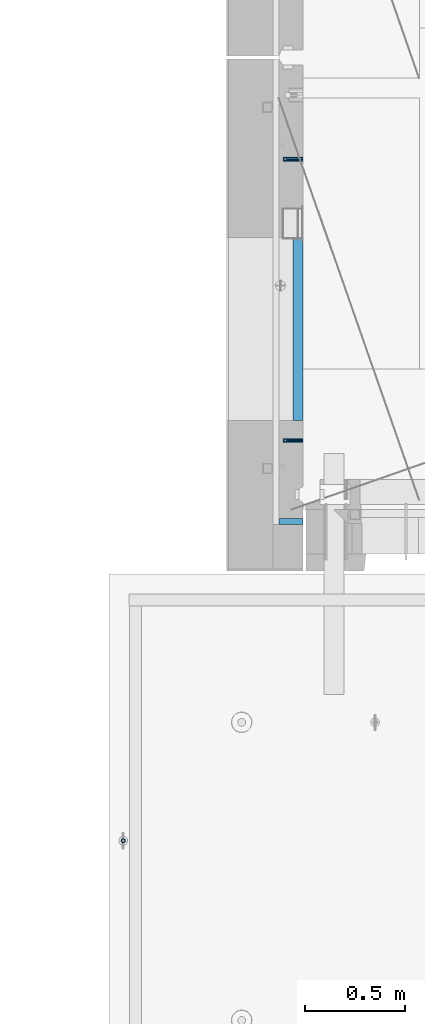
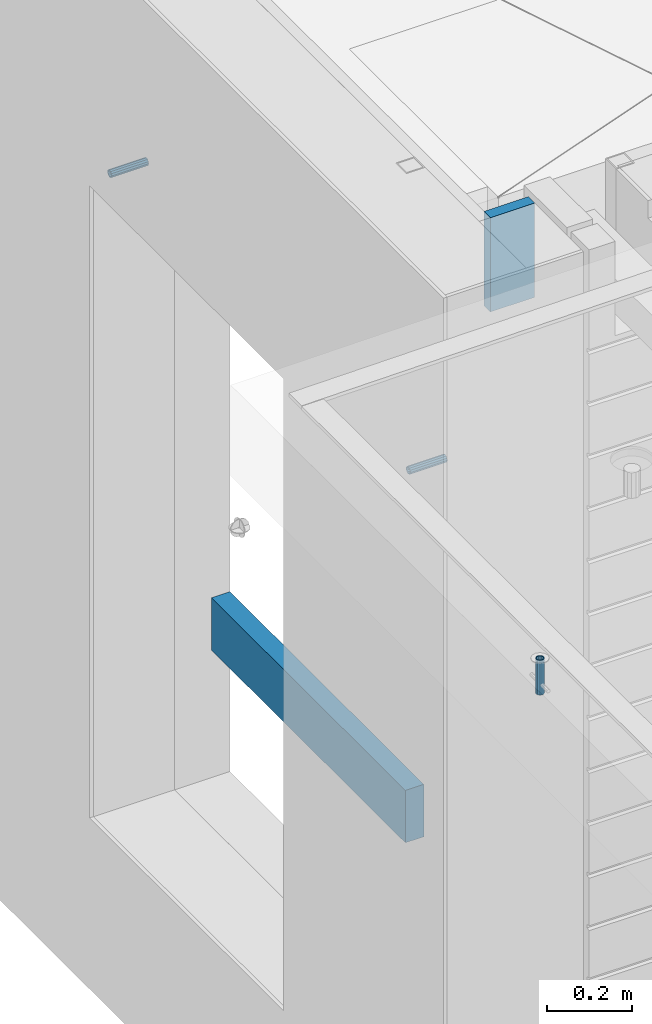
# One storey, part 138 of 350: 5 beams, 5 elements without a shape of their own.
"""IFC2X3 building model written with IfcOpenShell, lengths in millimetres."""

from ifc_helpers import new_model, si_unit, frame, origin_with_axes, place, context, subcontext, project, spatial, faceted_brep, material, type_object, element, aggregate, save


model = new_model("IFC2X3")

# Units and contexts
model_context = context("Model", 3, precision=1e-05, world=origin_with_axes())
body_context = subcontext(model_context, "Body", "Model", "MODEL_VIEW")
ifc_project = project(units=[si_unit("LENGTHUNIT", "METRE", prefix="MILLI"), si_unit("AREAUNIT", "SQUARE_METRE"), si_unit("VOLUMEUNIT", "CUBIC_METRE"), si_unit("MASSUNIT", "GRAM", prefix="KILO"), si_unit("TIMEUNIT", "SECOND"), si_unit("PLANEANGLEUNIT", "RADIAN"), si_unit("SOLIDANGLEUNIT", "STERADIAN"), si_unit("THERMODYNAMICTEMPERATUREUNIT", "DEGREE_CELSIUS"), si_unit("LUMINOUSINTENSITYUNIT", "LUMEN")], contexts=[model_context])

# Site, building, storey
site_placement = place(None, origin_with_axes())
site = spatial("IfcSite", under=ifc_project, at=site_placement, CompositionType="ELEMENT")
building_placement = place(site_placement, origin_with_axes())
building = spatial("IfcBuilding", under=site, at=building_placement, CompositionType="ELEMENT")
storey_placement = place(building_placement, origin_with_axes())
storey = spatial("IfcBuildingStorey", under=building, at=storey_placement, Name="2", CompositionType="ELEMENT", Elevation=0.0)

# Assemblies, beams
assembly_1_placement = place(storey_placement, origin_with_axes())
assembly_1 = element("IfcElementAssembly", 1, at=assembly_1_placement, inside=storey, AssemblyPlace="NOTDEFINED", PredefinedType="REINFORCEMENT_UNIT")
assembly_2_placement = place(assembly_1_placement, origin_with_axes())
assembly_2 = element("IfcElementAssembly", 2, at=assembly_2_placement, Name="Steel Assembly", AssemblyPlace="NOTDEFINED", PredefinedType="RIGID_FRAME")
ifc_material_1 = material(Name="STEEL/Steel_Undefined")
beam_type_1 = type_object("IfcBeamType", PredefinedType="NOTDEFINED")
beam_1_placement = place(assembly_2_placement, frame((7999.99979286169, 12695.8445842197, 86755.0), z_axis=(0.0, 1.0, 0.0), x_axis=(-1.0, 3.00000001838171e-08, 0.0)))
beam_1 = element("IfcBeam", 3, at=beam_1_placement, type_object=beam_type_1, material=ifc_material_1, Name="M16", context=body_context, shape_type="Brep", body=[
    faceted_brep([(0.0, -8.49999999999272, -1.45519152283669e-11), (0.0, -7.36121593215648, 4.24999999998545), (100.000000000262, -7.36121593215648, 4.24999999998545), (100.000000000262, -8.49999999999272, -1.45519152283669e-11), (0.0, -4.24999999998545, 7.36121593216376), (100.000000000262, -4.24999999998545, 7.36121593216376), (0.0, 1.45519152283669e-11, 8.49999999998545), (100.000000000262, 1.45519152283669e-11, 8.49999999998545), (0.0, 4.25000000001455, 7.36121593216376), (100.000000000262, 4.25000000001455, 7.36121593216376), (0.0, 7.36121593217104, 4.24999999998545), (100.000000000262, 7.36121593217104, 4.24999999998545), (0.0, 8.50000000000728, 0.0), (100.000000000262, 8.50000000000728, 0.0), (0.0, 7.36121593217104, -4.25000000001455), (100.000000000262, 7.36121593217104, -4.25000000001455), (0.0, 4.25000000000728, -7.36121593219286), (100.000000000262, 4.25000000000728, -7.36121593219286), (0.0, 7.27595761418343e-12, -8.5), (100.000000000262, 7.27595761418343e-12, -8.5), (0.0, -4.24999999999272, -7.36121593217831), (100.000000000262, -4.24999999999272, -7.36121593217831), (0.0, -7.36121593215648, -4.25), (100.000000000262, -7.36121593215648, -4.25), (0.0, -10.4999999999927, -1.45519152283669e-11), (0.0, -9.09326673972828, -5.25000000001455), (100.000000000262, -9.09326673972828, -5.25000000001455), (100.000000000262, -10.4999999999927, -1.45519152283669e-11), (0.0, -5.24999999998545, -9.09326673974283), (100.000000000262, -5.24999999998545, -9.09326673974283), (0.0, 7.27595761418343e-12, -10.5), (100.000000000262, 7.27595761418343e-12, -10.5), (0.0, 5.25000000001455, -9.09326673975738), (100.000000000262, 5.25000000001455, -9.09326673975738), (0.0, 9.09326673975011, -5.25000000001455), (100.000000000262, 9.09326673975011, -5.25000000001455), (0.0, 10.5000000000073, -1.45519152283669e-11), (100.000000000262, 10.5000000000073, -1.45519152283669e-11), (0.0, 9.09326673975011, 5.25), (100.000000000262, 9.09326673975011, 5.25), (0.0, 5.25000000000728, 9.09326673972828), (100.000000000262, 5.25000000000728, 9.09326673972828), (0.0, 1.45519152283669e-11, 10.4999999999854), (100.000000000262, 1.45519152283669e-11, 10.4999999999854), (0.0, -5.24999999999272, 9.09326673972828), (100.000000000262, -5.24999999999272, 9.09326673972828), (0.0, -9.09326673972828, 5.24999999998545), (100.000000000262, -9.09326673972828, 5.24999999998545)], [[[0, 1, 2, 3]], [[1, 4, 5, 2]], [[4, 6, 7, 5]], [[6, 8, 9, 7]], [[8, 10, 11, 9]], [[10, 12, 13, 11]], [[12, 14, 15, 13]], [[14, 16, 17, 15]], [[16, 18, 19, 17]], [[18, 20, 21, 19]], [[20, 22, 23, 21]], [[22, 0, 3, 23]], [[24, 25, 26, 27]], [[25, 28, 29, 26]], [[28, 30, 31, 29]], [[30, 32, 33, 31]], [[32, 34, 35, 33]], [[34, 36, 37, 35]], [[36, 38, 39, 37]], [[38, 40, 41, 39]], [[40, 42, 43, 41]], [[42, 44, 45, 43]], [[44, 46, 47, 45]], [[46, 24, 27, 47]], [[29, 31, 33, 35, 37, 39, 41, 43, 45, 47, 27, 26], [5, 7, 9, 11, 13, 15, 17, 19, 21, 23, 3, 2]], [[46, 44, 42, 40, 38, 36, 34, 32, 30, 28, 25, 24], [22, 20, 18, 16, 14, 12, 10, 8, 6, 4, 1, 0]]]),
])
aggregate(assembly_2, [beam_1])
assembly_3_placement = place(assembly_1_placement, origin_with_axes())
assembly_3 = element("IfcElementAssembly", 4, at=assembly_3_placement, Name="Steel Assembly", AssemblyPlace="NOTDEFINED", PredefinedType="RIGID_FRAME")
beam_2_placement = place(assembly_3_placement, frame((7999.99997194106, 11295.0002221546, 86755.0), z_axis=(0.0, -1.0, 0.0), x_axis=(-1.0, 3.00000001838171e-08, 0.0)))
beam_2 = element("IfcBeam", 5, at=beam_2_placement, type_object=beam_type_1, material=ifc_material_1, Name="M16", context=body_context, shape_type="Brep", body=[
    faceted_brep([(0.0, -8.49999999999272, -1.45519152283669e-11), (0.0, -7.36121593215648, 4.24999999998545), (100.000000000262, -7.36121593215648, 4.24999999998545), (100.000000000262, -8.49999999999272, -1.45519152283669e-11), (0.0, -4.24999999998545, 7.36121593216376), (100.000000000262, -4.24999999998545, 7.36121593216376), (0.0, 1.45519152283669e-11, 8.49999999998545), (100.000000000262, 1.45519152283669e-11, 8.49999999998545), (0.0, 4.25000000001455, 7.36121593216376), (100.000000000262, 4.25000000001455, 7.36121593216376), (0.0, 7.36121593217104, 4.24999999998545), (100.000000000262, 7.36121593217104, 4.24999999998545), (0.0, 8.50000000000728, 0.0), (100.000000000262, 8.50000000000728, 0.0), (0.0, 7.36121593217104, -4.25000000001455), (100.000000000262, 7.36121593217104, -4.25000000001455), (0.0, 4.25000000000728, -7.36121593219286), (100.000000000262, 4.25000000000728, -7.36121593219286), (0.0, 7.27595761418343e-12, -8.5), (100.000000000262, 7.27595761418343e-12, -8.5), (0.0, -4.24999999999272, -7.36121593217831), (100.000000000262, -4.24999999999272, -7.36121593217831), (0.0, -7.36121593215648, -4.25), (100.000000000262, -7.36121593215648, -4.25), (0.0, -10.4999999999927, -1.45519152283669e-11), (0.0, -9.09326673972828, -5.25000000001455), (100.000000000262, -9.09326673972828, -5.25000000001455), (100.000000000262, -10.4999999999927, -1.45519152283669e-11), (0.0, -5.24999999998545, -9.09326673974283), (100.000000000262, -5.24999999998545, -9.09326673974283), (0.0, 7.27595761418343e-12, -10.5), (100.000000000262, 7.27595761418343e-12, -10.5), (0.0, 5.25000000001455, -9.09326673975738), (100.000000000262, 5.25000000001455, -9.09326673975738), (0.0, 9.09326673975011, -5.25000000001455), (100.000000000262, 9.09326673975011, -5.25000000001455), (0.0, 10.5000000000073, -1.45519152283669e-11), (100.000000000262, 10.5000000000073, -1.45519152283669e-11), (0.0, 9.09326673975011, 5.25), (100.000000000262, 9.09326673975011, 5.25), (0.0, 5.25000000000728, 9.09326673972828), (100.000000000262, 5.25000000000728, 9.09326673972828), (0.0, 1.45519152283669e-11, 10.4999999999854), (100.000000000262, 1.45519152283669e-11, 10.4999999999854), (0.0, -5.24999999999272, 9.09326673972828), (100.000000000262, -5.24999999999272, 9.09326673972828), (0.0, -9.09326673972828, 5.24999999998545), (100.000000000262, -9.09326673972828, 5.24999999998545)], [[[0, 1, 2, 3]], [[1, 4, 5, 2]], [[4, 6, 7, 5]], [[6, 8, 9, 7]], [[8, 10, 11, 9]], [[10, 12, 13, 11]], [[12, 14, 15, 13]], [[14, 16, 17, 15]], [[16, 18, 19, 17]], [[18, 20, 21, 19]], [[20, 22, 23, 21]], [[22, 0, 3, 23]], [[24, 25, 26, 27]], [[25, 28, 29, 26]], [[28, 30, 31, 29]], [[30, 32, 33, 31]], [[32, 34, 35, 33]], [[34, 36, 37, 35]], [[36, 38, 39, 37]], [[38, 40, 41, 39]], [[40, 42, 43, 41]], [[42, 44, 45, 43]], [[44, 46, 47, 45]], [[46, 24, 27, 47]], [[29, 31, 33, 35, 37, 39, 41, 43, 45, 47, 27, 26], [5, 7, 9, 11, 13, 15, 17, 19, 21, 23, 3, 2]], [[46, 44, 42, 40, 38, 36, 34, 32, 30, 28, 25, 24], [22, 20, 18, 16, 14, 12, 10, 8, 6, 4, 1, 0]]]),
])
aggregate(assembly_3, [beam_2])

# Assemblies, beam
assembly_4_placement = place(storey_placement, origin_with_axes())
assembly_4 = element("IfcElementAssembly", 6, at=assembly_4_placement, inside=storey, AssemblyPlace="NOTDEFINED", PredefinedType="REINFORCEMENT_UNIT")
assembly_5_placement = place(assembly_4_placement, origin_with_axes())
assembly_5 = element("IfcElementAssembly", 7, at=assembly_5_placement, Name="Steel Assembly", AssemblyPlace="NOTDEFINED", PredefinedType="RIGID_FRAME")
aggregate(assembly_4, [assembly_5])
ifc_material_2 = material(Name="STEEL/1.4301")
beam_type_2 = type_object("IfcBeamType", PredefinedType="NOTDEFINED")
beam_3_placement = place(assembly_5_placement, frame((7104.95302979293, 9299.99671368706, 87706.0000000179), z_axis=(0.999999999993412, 3.63000011325366e-06, 0.0), x_axis=(0.0, -4.36599999292741e-06, -0.999999999990469)))
beam_3 = element("IfcBeam", 8, at=beam_3_placement, type_object=beam_type_2, material=ifc_material_2, context=body_context, shape_type="Brep", body=[
    faceted_brep([(0.0, -8.0, 0.0), (0.0, -6.92820323027263, 4.0), (100.000000000029, -6.92820323027263, 4.0), (100.000000000029, -7.99999999999636, 0.0), (0.0, -4.0, 6.92820323027627), (100.000000000029, -4.0, 6.92820323027536), (0.0, 0.0, 8.0), (100.000000000029, 3.63797880709171e-12, 8.0), (0.0, 4.0, 6.92820323027627), (100.000000000029, 4.0, 6.92820323027536), (0.0, 6.92820323027263, 4.0), (100.000000000029, 6.92820323027627, 3.99999999999909), (0.0, 8.0, 0.0), (100.000000000029, 8.0, 0.0), (0.0, 6.92820323027263, -4.0), (100.000000000029, 6.92820323027627, -4.00000000000091), (0.0, 4.0, -6.92820323027627), (100.000000000029, 4.00000000000364, -6.92820323027536), (0.0, 0.0, -8.0), (100.000000000029, 3.63797880709171e-12, -8.00000000000091), (0.0, -4.0, -6.92820323027627), (100.000000000029, -3.99999999999636, -6.92820323027627), (0.0, -6.92820323027263, -4.0), (100.000000000029, -6.92820323027263, -4.0), (0.0, -10.4999999999927, -1.45519152283669e-11), (0.0, -9.09326673972828, -5.25000000001455), (100.000000000262, -9.09326673972828, -5.25000000001455), (100.000000000262, -10.4999999999927, -1.45519152283669e-11), (0.0, -5.24999999998545, -9.09326673974283), (100.000000000262, -5.24999999998545, -9.09326673974283), (0.0, 7.27595761418343e-12, -10.5), (100.000000000262, 7.27595761418343e-12, -10.5), (0.0, 5.25000000001455, -9.09326673975738), (100.000000000262, 5.25000000001455, -9.09326673975738), (0.0, 9.09326673975011, -5.25000000001455), (100.000000000262, 9.09326673975011, -5.25000000001455), (0.0, 10.5000000000073, -1.45519152283669e-11), (100.000000000262, 10.5000000000073, -1.45519152283669e-11), (0.0, 9.09326673975011, 5.25), (100.000000000262, 9.09326673975011, 5.25), (0.0, 5.25000000000728, 9.09326673972828), (100.000000000262, 5.25000000000728, 9.09326673972828), (0.0, 1.45519152283669e-11, 10.4999999999854), (100.000000000262, 1.45519152283669e-11, 10.4999999999854), (0.0, -5.24999999999272, 9.09326673972828), (100.000000000262, -5.24999999999272, 9.09326673972828), (0.0, -9.09326673972828, 5.24999999998545), (100.000000000262, -9.09326673972828, 5.24999999998545)], [[[0, 1, 2, 3]], [[1, 4, 5, 2]], [[4, 6, 7, 5]], [[6, 8, 9, 7]], [[8, 10, 11, 9]], [[10, 12, 13, 11]], [[12, 14, 15, 13]], [[14, 16, 17, 15]], [[16, 18, 19, 17]], [[18, 20, 21, 19]], [[20, 22, 23, 21]], [[22, 0, 3, 23]], [[24, 25, 26, 27]], [[25, 28, 29, 26]], [[28, 30, 31, 29]], [[30, 32, 33, 31]], [[32, 34, 35, 33]], [[34, 36, 37, 35]], [[36, 38, 39, 37]], [[38, 40, 41, 39]], [[40, 42, 43, 41]], [[42, 44, 45, 43]], [[44, 46, 47, 45]], [[46, 24, 27, 47]], [[29, 31, 33, 35, 37, 39, 41, 43, 45, 47, 27, 26], [5, 7, 9, 11, 13, 15, 17, 19, 21, 23, 3, 2]], [[46, 44, 42, 40, 38, 36, 34, 32, 30, 28, 25, 24], [22, 20, 18, 16, 14, 12, 10, 8, 6, 4, 1, 0]]]),
])
aggregate(assembly_5, [beam_3])

# Beam
ifc_material_3 = material(Name="TIMBER/T24")
beam_type_3 = type_object("IfcBeamType", PredefinedType="NOTDEFINED")
beam_4_placement = place(assembly_1_placement, frame((7975.00000026382, 12305.0002963341, 85685.0), z_axis=(0.0, 0.0, 1.0), x_axis=(0.0, -1.0, 0.0)))
beam_4 = element("IfcBeam", 9, at=beam_4_placement, type_object=beam_type_3, material=ifc_material_3, context=body_context, shape_type="Brep", body=[
    faceted_brep([(-3.63797880709171e-12, 24.9999999999964, -75.0), (-3.63797880709171e-12, 24.9999999999964, 75.0), (909.999999999993, 25.0, 75.0), (909.999999999993, 25.0, -75.0), (0.0, -25.0000000000073, 75.0), (909.999999999993, -25.0, 75.0), (0.0, -25.0000000000073, -75.0), (909.999999999993, -25.0, -75.0)], [[[0, 1, 2, 3]], [[1, 4, 5, 2]], [[4, 6, 7, 5]], [[6, 0, 3, 7]], [[5, 7, 3, 2]], [[6, 4, 1, 0]]]),
])

ifc_material_4 = material(Name="CONCRETE/C25/30")
beam_type_4 = type_object("IfcBeamType", Name="270X30", PredefinedType="NOTDEFINED")
beam_5_placement = place(assembly_1_placement, frame((7880.00002749681, 10889.9997019753, 87604.9999999983), z_axis=(0.0, 0.0, 1.0), x_axis=(1.0, 0.0, 0.0)))
beam_5 = element("IfcBeam", 10, at=beam_5_placement, type_object=beam_type_4, material=ifc_material_4, ObjectType="270X30", context=body_context, shape_type="Brep", body=[
    faceted_brep([(0.0, 15.0, -135.0), (0.0, 15.0, 135.0), (119.999999999978, 15.0, 135.0), (119.999999999978, 15.0, -135.0), (0.0, -15.0, 135.0), (119.999999999978, -15.0, 135.0), (0.0, -15.0, -135.0), (119.999999999978, -15.0, -135.0)], [[[0, 1, 2, 3]], [[1, 4, 5, 2]], [[4, 6, 7, 5]], [[6, 0, 3, 7]], [[5, 7, 3, 2]], [[6, 4, 1, 0]]]),
])

aggregate(assembly_1, [assembly_2, assembly_3, beam_5, beam_4])

save(model, "model.ifc")
